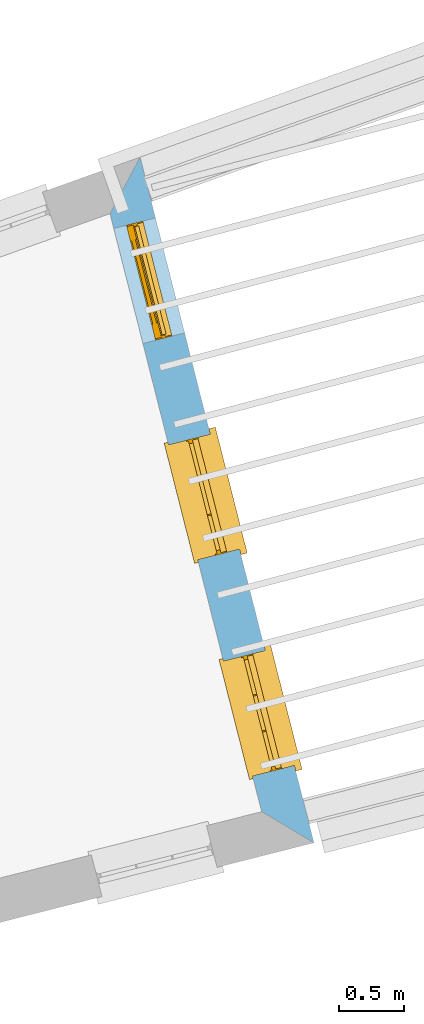
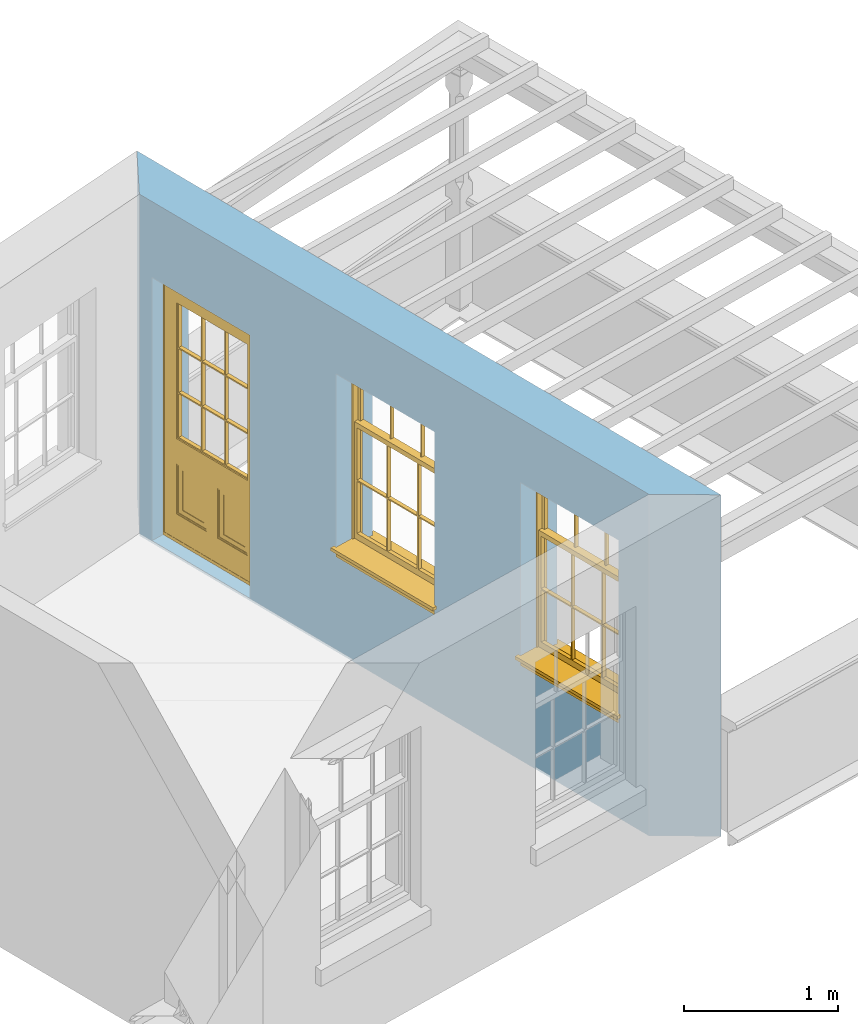
# One storey, part 8 of 10: 2 windows, 1 door, 3 openings, plus 1 element that does not belong to this part.
"""IFC2X3 building model written with IfcOpenShell, lengths in metres."""

import ifcopenshell
import ifcopenshell.guid

model = None  # the IFC model being written
_history = None  # IfcOwnerHistory: only IFC2X3 demands one
_inside = {}  # id of a spatial element -> (the spatial element, [elements in it])
_under = {}  # id of a project, library or spatial element -> (it, [spatial elements below it])
_declared = {}  # id of a project -> (the project, [libraries it declares])
_typed = {}  # id of a type object -> (the type object, [elements of that type])
_made_of = {}  # id of a material, layer set ... -> (it, [elements and type objects made of it])


def new_model(schema):
    """Start an empty IFC model of exactly this schema.

    Asked for "IFC4X3", IfcOpenShell would pick the latest addendum, in which some entities
    have other attributes; the version numbers below select the first issue.
    IFC2X3 requires an IfcOwnerHistory on every rooted entity: one is made here for all.
    """
    global model, _history
    if schema == "IFC4X3":
        model = ifcopenshell.file(schema_version=(4, 3, 0, 0))
    else:
        model = ifcopenshell.file(schema=schema)
    _inside.clear()
    _under.clear()
    _declared.clear()
    _typed.clear()
    _made_of.clear()
    _history = None
    if model.schema == "IFC2X3":
        org = make("IfcOrganization", Name="unknown")
        user = make(
            "IfcPersonAndOrganization",
            ThePerson=make("IfcPerson", FamilyName="unknown"),
            TheOrganization=org,
        )
        app = make(
            "IfcApplication",
            ApplicationDeveloper=org,
            Version="unknown",
            ApplicationFullName="unknown",
            ApplicationIdentifier="unknown",
        )
        _history = make(
            "IfcOwnerHistory",
            OwningUser=user,
            OwningApplication=app,
            ChangeAction="ADDED",
            CreationDate=0,
        )
    return model


def make(cls, **values):
    """One entity of the class cls with the attributes given. An attribute that is None is left unset."""
    return model.create_entity(
        cls, **{name: value for name, value in values.items() if value is not None}
    )


def rooted(cls, **values):
    """An entity with a GlobalId (a new one), such as an element, a storey or a relation."""
    return make(cls, GlobalId=ifcopenshell.guid.new(), OwnerHistory=_history, **values)


def si_unit(unit_type, name, prefix=None):
    """IfcSIUnit, for example si_unit("LENGTHUNIT", "METRE", prefix="MILLI")."""
    return make("IfcSIUnit", UnitType=unit_type, Prefix=prefix, Name=name)


def assignment(units):
    """IfcUnitAssignment: the units of a project."""
    return None if units is None else make("IfcUnitAssignment", Units=units)


def point(xyz):
    """IfcCartesianPoint."""
    return None if xyz is None else make("IfcCartesianPoint", Coordinates=xyz)


def direction(xyz):
    """IfcDirection."""
    return None if xyz is None else make("IfcDirection", DirectionRatios=xyz)


def frame(location, z_axis=None, x_axis=None):
    """IfcAxis2Placement3D, a coordinate frame: its origin and axes. An axis left out is left unset."""
    return make(
        "IfcAxis2Placement3D",
        Location=point(location),
        Axis=direction(z_axis),
        RefDirection=direction(x_axis),
    )


def origin():
    """The frame at (0, 0, 0) with its axes left unset."""
    return frame((0.0, 0.0, 0.0))


def place(relative_to, where):
    """IfcLocalPlacement: puts the frame where relative to a parent placement (None: the world)."""
    return make(
        "IfcLocalPlacement", PlacementRelTo=relative_to, RelativePlacement=where
    )


def context(
    kind, dimensions, precision=None, world=None, true_north=None, identifier=None
):
    """IfcGeometricRepresentationContext, for example the 3D "Model" context."""
    return make(
        "IfcGeometricRepresentationContext",
        ContextIdentifier=identifier,
        ContextType=kind,
        CoordinateSpaceDimension=dimensions,
        Precision=precision,
        WorldCoordinateSystem=world,
        TrueNorth=true_north,
    )


def subcontext(parent, identifier, kind, view, scale=None):
    """IfcGeometricRepresentationSubContext, for example "Body" below "Model"."""
    return make(
        "IfcGeometricRepresentationSubContext",
        ContextIdentifier=identifier,
        ContextType=kind,
        ParentContext=parent,
        TargetScale=scale,
        TargetView=view,
    )


def project(units=None, contexts=None):
    """IfcProject with its units and contexts."""
    return rooted(
        "IfcProject",
        Name="project",
        RepresentationContexts=contexts,
        UnitsInContext=assignment(units),
    )


def spatial(cls, under=None, at=None, **own):
    """A site, building, storey or space (cls), placed at a placement, below another one or the project."""
    s = rooted(cls, ObjectPlacement=at, **own)
    if under is not None:
        _under.setdefault(under.id(), (under, []))[1].append(s)
    return s


def polyline(points):
    """IfcPolyline through the points."""
    return make("IfcPolyline", Points=[point(p) for p in points])


def outline(outer, holes=None, kind="AREA"):
    """IfcArbitraryClosedProfileDef: a profile drawn as a closed curve; with holes, ...WithVoids."""
    if holes is None:
        return make("IfcArbitraryClosedProfileDef", ProfileType=kind, OuterCurve=outer)
    return make(
        "IfcArbitraryProfileDefWithVoids",
        ProfileType=kind,
        OuterCurve=outer,
        InnerCurves=holes,
    )


def extrude(swept, where, along, depth):
    """IfcExtrudedAreaSolid: the profile swept, set in the frame where, extruded along a direction by depth."""
    return make(
        "IfcExtrudedAreaSolid",
        SweptArea=swept,
        Position=where,
        ExtrudedDirection=direction(along),
        Depth=depth,
    )


def faces_of(points, faces, orient=None, outer=None):
    """IfcFace entities. A face is a list of loops; a loop is a list of indices into points, from 0.

    orient and outer hold one flag for each loop. By default every Orientation is true, the
    first loop of a face is its IfcFaceOuterBound and the others are IfcFaceBound.
    """
    made = []
    for i, loops in enumerate(faces):
        bounds = []
        for j, loop in enumerate(loops):
            is_outer = j == 0 if outer is None else outer[i][j]
            bounds.append(
                make(
                    "IfcFaceOuterBound" if is_outer else "IfcFaceBound",
                    Bound=make("IfcPolyLoop", Polygon=[points[k] for k in loop]),
                    Orientation=True if orient is None else orient[i][j],
                )
            )
        made.append(make("IfcFace", Bounds=bounds))
    return made


def faceted_brep(points, faces, orient=None, outer=None, voids=None):
    """IfcFacetedBrep: a solid bounded by flat faces; with voids (closed shells), ...WithVoids."""
    shared = [point(p) for p in points]
    hull = make("IfcClosedShell", CfsFaces=faces_of(shared, faces, orient, outer))
    if voids is None:
        return make("IfcFacetedBrep", Outer=hull)
    return make(
        "IfcFacetedBrepWithVoids",
        Outer=hull,
        Voids=[
            make(cls, CfsFaces=faces_of(shared, fs, o, b)) for cls, fs, o, b in voids
        ],
    )


def shape(context_of_items, identifier, shape_type, items):
    """IfcShapeRepresentation: the items that make up one representation, for example the "Body"."""
    return make(
        "IfcShapeRepresentation",
        ContextOfItems=context_of_items,
        RepresentationIdentifier=identifier,
        RepresentationType=shape_type,
        Items=items,
    )


def material(Name=None, Category=None):
    """IfcMaterial."""
    return make("IfcMaterial", Name=Name, Category=Category)


def layer(
    of_material, thickness, ventilated=None, Name=None, Category=None, Priority=None
):
    """IfcMaterialLayer: one layer of a wall or slab, of a material (None: an air gap)."""
    return make(
        "IfcMaterialLayer",
        Material=of_material,
        LayerThickness=thickness,
        IsVentilated=ventilated,
        Name=Name,
        Category=Category,
        Priority=Priority,
    )


def layer_set(layers, Name=None):
    """IfcMaterialLayerSet."""
    return make("IfcMaterialLayerSet", MaterialLayers=layers, LayerSetName=Name)


def layer_usage(for_layer_set, set_direction, sense, offset, extent=None):
    """IfcMaterialLayerSetUsage: how a layer set lies in its element."""
    return make(
        "IfcMaterialLayerSetUsage",
        ForLayerSet=for_layer_set,
        LayerSetDirection=set_direction,
        DirectionSense=sense,
        OffsetFromReferenceLine=offset,
        ReferenceExtent=extent,
    )


def made_of(thing, what):
    """Note that an element or type object is made of a material, layer set ...; save() writes the relation."""
    if what is not None:
        _made_of.setdefault(what.id(), (what, []))[1].append(thing)
    return thing


def element(
    cls,
    number,
    at=None,
    inside=None,
    cuts=None,
    type_object=None,
    material=None,
    context=None,
    identifier="Body",
    shape_type=None,
    held_by="IfcProductDefinitionShape",
    body=None,
    shapes=None,
    **own,
):
    """One element of the class cls, such as IfcWall. Its Tag is "e" and its number.

    at: its placement. inside: the storey or other place that contains it. cuts: it is an
    opening in that element (IfcRelVoidsElement). A single representation is given by context,
    identifier, shape_type and body (its items); several are given by shapes. held_by: the class
    of the entity that holds the representations. save() writes the other relations.
    """
    e = rooted(cls, Tag="e%d" % number, ObjectPlacement=at, **own)
    if body is not None:
        shapes = [shape(context, identifier, shape_type, body)]
    if shapes is not None:
        e.Representation = make(held_by, Representations=shapes)
    if inside is not None:
        _inside.setdefault(inside.id(), (inside, []))[1].append(e)
    if cuts is not None:
        rooted(
            "IfcRelVoidsElement", RelatingBuildingElement=cuts, RelatedOpeningElement=e
        )
    if type_object is not None:
        _typed.setdefault(type_object.id(), (type_object, []))[1].append(e)
    return made_of(e, material)


def fill(opening, filler):
    """IfcRelFillsElement: the door or window that sits in an opening."""
    return rooted(
        "IfcRelFillsElement",
        RelatingOpeningElement=opening,
        RelatedBuildingElement=filler,
    )


def aggregate(whole, parts):
    """IfcRelAggregates: a whole, such as a stair, and the parts it consists of."""
    return rooted("IfcRelAggregates", RelatingObject=whole, RelatedObjects=parts)


def save(model, path):
    """Write the relations noted so far, then the file.

    IfcRelAggregates (storeys below a building ...), IfcRelContainedInSpatialStructure (elements
    in a storey), IfcRelDefinesByType, IfcRelAssociatesMaterial and IfcRelDeclares: one each for
    every whole, place, type object, material and project.
    """
    for whole, parts in _under.values():
        aggregate(whole, parts)
    for where, things in _inside.values():
        rooted(
            "IfcRelContainedInSpatialStructure",
            RelatedElements=things,
            RelatingStructure=where,
        )
    for kind, things in _typed.values():
        rooted("IfcRelDefinesByType", RelatedObjects=things, RelatingType=kind)
    for what, things in _made_of.values():
        rooted("IfcRelAssociatesMaterial", RelatedObjects=things, RelatingMaterial=what)
    for by, libraries in _declared.values():
        rooted("IfcRelDeclares", RelatingContext=by, RelatedDefinitions=libraries)
    model.write(path)


model = new_model("IFC2X3")

# Units and contexts
model_context = context("Model", 3, world=origin())
body_context = subcontext(model_context, "Body", "Model", "MODEL_VIEW")
ifc_project = project(units=[si_unit("PLANEANGLEUNIT", "RADIAN"), si_unit("MASSUNIT", "GRAM", prefix="KILO"), si_unit("FORCEUNIT", "NEWTON", prefix="KILO"), si_unit("LENGTHUNIT", "METRE")], contexts=[model_context])

# Site, building, storey
site_placement = place(None, origin())
site = spatial("IfcSite", under=ifc_project, at=site_placement, CompositionType="ELEMENT")
building_placement = place(None, origin())
building = spatial("IfcBuilding", under=site, at=building_placement, Name="Building plot-13", CompositionType="ELEMENT")
storey_placement = place(None, frame((0.0, 0.0, 9.55)))
storey = spatial("IfcBuildingStorey", under=building, at=storey_placement, Name="Floor 2", CompositionType="ELEMENT", Elevation=9.55)

# Wall, openings, windows, door
ifc_material = material(Name="Masonry")
ifc_layer = layer(ifc_material, 0.33, ventilated=False)
ifc_layer_set = layer_set([ifc_layer], Name="My Wall")
ifc_layer_usage = layer_usage(ifc_layer_set, "AXIS2", "NEGATIVE", 0.08)
wall_placement = place(storey_placement, origin())
wall = element("IfcWallStandardCase", 1, at=wall_placement, inside=storey, material=ifc_layer_usage, Name="exterior", context=body_context, shape_type="SweptSolid", body=[
    extrude(outline(polyline([(76.8445718371103, 46.4530457942866), (77.2455722633567, 46.2143018767719), (75.9129314952901, 51.4686328142499), (75.6822868035305, 51.0356987915879), (76.8445718371103, 46.4530457942866)])), origin(), (0.0, 0.0, 1.0), 2.7),
])
opening_1_placement = place(storey_placement, frame((0.0, 0.0, 0.75)))
opening_1 = element("IfcOpeningElement", 2, at=opening_1_placement, cuts=wall, Name="Opening", ObjectType="Opening", context=body_context, shape_type="SweptSolid", body=[
    extrude(outline(polyline([(77.0953728860989, 46.8065074085449), (76.8716555786053, 47.6885791552457), (76.5517834067248, 47.6074509008799), (76.7755007142184, 46.7253791541791), (77.0953728860989, 46.8065074085449)])), origin(), (0.0, 0.0, 1.0), 1.445),
])
opening_2_placement = place(storey_placement, frame((0.0, 0.0, 0.75)))
opening_2 = element("IfcOpeningElement", 3, at=opening_2_placement, cuts=wall, Name="Opening", ObjectType="Opening", context=body_context, shape_type="SweptSolid", body=[
    extrude(outline(polyline([(76.6749810225669, 48.464026844653), (76.4512637150733, 49.3460985913538), (76.1313915431928, 49.264970336988), (76.3551088506864, 48.3828985902872), (76.6749810225669, 48.464026844653)])), origin(), (0.0, 0.0, 1.0), 1.445),
])
opening_3_placement = place(storey_placement, frame((0.0, 0.0, 0.0199999999999996)))
opening_3 = element("IfcOpeningElement", 4, at=opening_3_placement, cuts=wall, Name="Opening", ObjectType="Opening", context=body_context, shape_type="SweptSolid", body=[
    extrude(outline(polyline([(76.2545891590349, 50.1215462807611), (76.0308718515412, 51.0036180274619), (75.7109996796607, 50.9224897730961), (75.9347169871544, 50.0404180263953), (76.2545891590349, 50.1215462807611)])), origin(), (0.0, 0.0, 1.0), 2.08),
])
window_1_placement = place(storey_placement, frame((76.8530454831591, 46.7450466097829, 0.75), z_axis=(0.0, 0.0, 1.0), x_axis=(-0.223717307493644, 0.882071746700802, 0.0)))
window_1 = element("IfcWindow", 5, at=window_1_placement, inside=storey, Name="bedroom outside window", OverallHeight=1.445, OverallWidth=0.91, context=body_context, shape_type="Brep", held_by="IfcProductRepresentation", body=[
    faceted_brep([(0.876875, -0.105, 0.999097), (0.876875, -0.105, 1.411875), (0.9, -0.105, 1.435), (0.033125, -0.105, 1.411875), (0.033125, -0.105, 0.999097), (0.01, -0.105, 1.435), (0.033125, -0.135, 1.411875), (0.01, -0.135, 1.435), (0.033125, -0.135, 0.999097), (0.876875, -0.135, 1.411875), (0.876875, -0.135, 0.999097), (0.9, -0.135, 1.435), (0.033125, -0.105, 0.960972), (0.01, -0.105, 0.960972), (0.033125, -0.105, 0.548195), (0.876875, -0.105, 0.960972), (0.876875, -0.105, 0.548195), (0.9, -0.105, 0.960972), (0.876875, -0.105, 0.538195), (0.876875, -0.105, 0.125417), (0.9, -0.105, 0.077167), (0.033125, -0.105, 0.125417), (0.033125, -0.105, 0.538195), (0.01, -0.105, 0.077167), (0.9, -0.135, 0.960972), (0.01, -0.135, 0.960972), (-0.0425, -0.25, 0.01), (-0.0425, -0.3, 0.001667), (0.0, -0.25, 0.01), (0.9525, -0.25, 0.01), (0.91, -0.25, 0.01), (0.9525, -0.3, 0.001667), (-0.02, 0.08, 0.077167), (0.0, 0.08, 0.077167), (-0.02, 0.11, 0.077167), (0.0, -0.06, 0.077167), (0.01, -0.06, 0.077167), (0.91, -0.06, 0.077167), (0.91, 0.08, 0.077167), (0.9, -0.06, 0.077167), (0.93, 0.08, 0.077167), (0.93, 0.11, 0.077167), (0.01, -0.105, 0.999097), (0.01, -0.075, 0.999097), (0.9, -0.105, 0.999097), (0.9, -0.075, 0.999097), (0.876875, -0.075, 0.125417), (0.876875, -0.075, 0.538195), (0.9, -0.075, 0.077167), (0.876875, -0.075, 0.548195), (0.876875, -0.075, 0.960972), (0.033125, -0.075, 0.125417), (0.01, -0.075, 0.077167), (0.033125, -0.075, 0.538195), (0.033125, -0.075, 0.960972), (0.033125, -0.075, 0.548195), (-0.02, 0.08, 0.052167), (-0.02, 0.11, 0.052167), (0.93, 0.11, 0.052167), (0.93, 0.08, 0.052167), (0.91, 0.08, 0.052167), (0.0, 0.08, 0.052167), (0.91, -0.15, 0.026667), (0.0, -0.15, 0.026667), (-0.0425, -0.3, -0.123333), (0.9525, -0.3, -0.123333), (-0.0425, -0.25, -0.123333), (0.9525, -0.25, -0.123333), (0.01, -0.06, 1.435), (0.9, -0.06, 1.435), (0.0, -0.06, 1.445), (0.91, -0.06, 1.445), (0.01, -0.15, 0.077167), (0.9, -0.15, 0.077167), (0.592292, -0.105, 0.125417), (0.592292, -0.075, 0.125417), (0.317708, -0.075, 0.125417), (0.317708, -0.105, 0.125417), (0.592292, -0.105, 0.548195), (0.317708, -0.105, 0.548195), (0.317708, -0.105, 0.538195), (0.592292, -0.105, 0.538195), (0.592292, -0.075, 0.548195), (0.317708, -0.075, 0.548195), (0.602292, -0.075, 0.548195), (0.602292, -0.105, 0.548195), (0.317708, -0.075, 0.538195), (0.307708, -0.075, 0.125417), (0.307708, -0.075, 0.538195), (0.602292, -0.075, 0.538195), (0.602292, -0.075, 0.125417), (0.592292, -0.075, 0.538195), (0.307708, -0.075, 0.548195), (0.317708, -0.075, 0.960972), (0.307708, -0.075, 0.960972), (0.602292, -0.075, 0.960972), (0.592292, -0.075, 0.960972), (0.307708, -0.105, 0.538195), (0.307708, -0.105, 0.125417), (0.307708, -0.105, 0.548195), (0.307708, -0.105, 0.960972), (0.592292, -0.105, 0.960972), (0.317708, -0.105, 0.960972), (0.602292, -0.105, 0.960972), (0.602292, -0.105, 0.538195), (0.602292, -0.105, 0.125417), (0.317708, -0.135, 1.411875), (0.307708, -0.135, 1.411875), (0.307708, -0.135, 0.999097), (0.317708, -0.135, 0.999097), (0.602292, -0.135, 1.411875), (0.592292, -0.135, 1.411875), (0.592292, -0.135, 0.999097), (0.602292, -0.135, 0.999097), (0.317708, -0.105, 0.999097), (0.307708, -0.105, 0.999097), (0.307708, -0.105, 1.411875), (0.317708, -0.105, 1.411875), (0.602292, -0.105, 0.999097), (0.592292, -0.105, 0.999097), (0.592292, -0.105, 1.411875), (0.602292, -0.105, 1.411875), (0.91, -0.15, 1.445), (0.9, -0.15, 1.435), (0.01, -0.15, 1.435), (0.0, -0.15, 1.445), (0.91, -0.25, 0.0), (0.0, -0.25, 0.0), (0.91, 0.08, 0.0), (0.0, 0.08, 0.0)], [[[0, 1, 2]], [[3, 4, 5]], [[6, 7, 8]], [[9, 10, 11]], [[12, 13, 14]], [[15, 16, 17]], [[18, 19, 20]], [[21, 22, 23]], [[24, 15, 17]], [[13, 12, 25]], [[26, 27, 28]], [[29, 30, 31]], [[32, 33, 34]], [[35, 36, 33]], [[37, 38, 39]], [[40, 41, 38]], [[42, 4, 43]], [[44, 45, 0]], [[46, 47, 48]], [[49, 50, 45]], [[51, 52, 53]], [[54, 55, 43]], [[38, 33, 36, 39]], [[41, 34, 33, 38]], [[56, 32, 34, 57]], [[57, 34, 41, 58]], [[58, 41, 40, 59]], [[57, 58, 60, 61]], [[52, 48, 39, 36]], [[62, 63, 28, 30]], [[27, 31, 30, 28]], [[27, 64, 65, 31]], [[66, 67, 65, 64]], [[2, 5, 68, 69]], [[68, 70, 71, 69]], [[20, 23, 72, 73]], [[73, 72, 63, 62]], [[74, 75, 76, 77]], [[78, 79, 80, 81]], [[78, 82, 83, 79]], [[16, 49, 84, 85]], [[86, 76, 87, 88]], [[89, 90, 75, 91]], [[92, 88, 53, 55]], [[82, 91, 86, 83]], [[93, 83, 92, 94]], [[95, 84, 82, 96]], [[89, 84, 49, 47]], [[97, 88, 87, 98]], [[22, 53, 88, 97]], [[81, 91, 75, 74]], [[80, 86, 91, 81]], [[77, 76, 86, 80]], [[99, 92, 55, 14]], [[100, 94, 92, 99]], [[101, 96, 82, 78]], [[79, 83, 93, 102]], [[85, 84, 95, 103]], [[104, 89, 47, 18]], [[105, 90, 89, 104]], [[104, 18, 16, 85]], [[80, 97, 98, 77]], [[104, 81, 74, 105]], [[103, 101, 78, 85]], [[99, 14, 22, 97]], [[102, 100, 99, 79]], [[106, 107, 108, 109]], [[110, 111, 112, 113]], [[114, 115, 116, 117]], [[118, 119, 120, 121]], [[107, 116, 115, 108]], [[111, 120, 119, 112]], [[109, 114, 117, 106]], [[113, 118, 121, 110]], [[85, 78, 81, 104]], [[84, 89, 91, 82]], [[83, 86, 88, 92]], [[79, 99, 97, 80]], [[109, 112, 119, 114]], [[102, 93, 96, 101]], [[106, 117, 120, 111]], [[98, 87, 51, 21]], [[6, 3, 116, 107]], [[110, 121, 1, 9]], [[19, 46, 90, 105]], [[26, 66, 64, 27]], [[29, 31, 65, 67]], [[25, 24, 112, 109]], [[11, 7, 106, 111]], [[75, 48, 52, 76]], [[43, 45, 96, 93]], [[45, 43, 114, 119]], [[5, 2, 120, 117]], [[24, 25, 102, 101]], [[42, 5, 4]], [[2, 44, 0]], [[49, 45, 48, 47]], [[52, 43, 55, 53]], [[14, 13, 23, 22]], [[20, 17, 16, 18]], [[24, 11, 10]], [[25, 8, 7]], [[8, 4, 3, 6]], [[9, 1, 0, 10]], [[15, 50, 49, 16]], [[18, 47, 46, 19]], [[21, 51, 53, 22]], [[14, 55, 54, 12]], [[44, 2, 69, 45]], [[68, 5, 42, 43]], [[36, 35, 70, 68]], [[39, 69, 71, 37]], [[62, 122, 123, 73]], [[63, 72, 124, 125]], [[8, 108, 115, 4]], [[113, 10, 0, 118]], [[94, 100, 12, 54]], [[17, 20, 73, 24]], [[72, 23, 13, 25]], [[52, 36, 68, 43]], [[69, 39, 48, 45]], [[11, 24, 73, 123]], [[7, 124, 72, 25]], [[23, 77, 98]], [[98, 21, 23]], [[105, 74, 20]], [[20, 19, 105]], [[20, 74, 77, 23]], [[113, 112, 24]], [[24, 10, 113]], [[25, 109, 108]], [[108, 8, 25]], [[110, 9, 11]], [[11, 111, 110]], [[7, 6, 107]], [[107, 106, 7]], [[5, 117, 116]], [[116, 3, 5]], [[121, 120, 2]], [[2, 1, 121]], [[11, 123, 124, 7]], [[122, 125, 124, 123]], [[43, 93, 94]], [[94, 54, 43]], [[96, 45, 95]], [[50, 95, 45]], [[15, 103, 95, 50]], [[48, 75, 90]], [[90, 46, 48]], [[87, 76, 52]], [[52, 51, 87]], [[103, 15, 24]], [[24, 101, 103]], [[100, 102, 25]], [[25, 12, 100]], [[115, 114, 43]], [[43, 4, 115]], [[118, 0, 45]], [[45, 119, 118]], [[71, 70, 125, 122]], [[70, 35, 63, 125]], [[122, 62, 37, 71]], [[126, 67, 66, 127]], [[60, 58, 59]], [[38, 60, 59, 40]], [[61, 56, 57]], [[32, 56, 61, 33]], [[61, 60, 128, 129]], [[62, 60, 38, 37]], [[126, 128, 60, 62]], [[33, 61, 63, 35]], [[61, 129, 127, 63]], [[128, 126, 127, 129]], [[28, 127, 66, 26]], [[63, 127, 28]], [[29, 67, 126, 30]], [[30, 126, 62]]]),
])
fill(opening_1, window_1)
window_2_placement = place(storey_placement, frame((76.4326536196271, 48.402566045891, 0.75), z_axis=(0.0, 0.0, 1.0), x_axis=(-0.223717307493644, 0.882071746700795, 0.0)))
window_2 = element("IfcWindow", 6, at=window_2_placement, inside=storey, Name="bedroom outside window", OverallHeight=1.445, OverallWidth=0.91, context=body_context, shape_type="Brep", held_by="IfcProductRepresentation", body=[
    faceted_brep([(0.876875, -0.105, 0.999097), (0.876875, -0.105, 1.411875), (0.9, -0.105, 1.435), (0.033125, -0.105, 1.411875), (0.033125, -0.105, 0.999097), (0.01, -0.105, 1.435), (0.033125, -0.135, 1.411875), (0.01, -0.135, 1.435), (0.033125, -0.135, 0.999097), (0.876875, -0.135, 1.411875), (0.876875, -0.135, 0.999097), (0.9, -0.135, 1.435), (0.033125, -0.105, 0.960972), (0.01, -0.105, 0.960972), (0.033125, -0.105, 0.548195), (0.876875, -0.105, 0.960972), (0.876875, -0.105, 0.548195), (0.9, -0.105, 0.960972), (0.876875, -0.105, 0.538195), (0.876875, -0.105, 0.125417), (0.9, -0.105, 0.077167), (0.033125, -0.105, 0.125417), (0.033125, -0.105, 0.538195), (0.01, -0.105, 0.077167), (0.9, -0.135, 0.960972), (0.01, -0.135, 0.960972), (-0.0425, -0.25, 0.01), (-0.0425, -0.3, 0.001667), (0.0, -0.25, 0.01), (0.9525, -0.25, 0.01), (0.91, -0.25, 0.01), (0.9525, -0.3, 0.001667), (-0.02, 0.08, 0.077167), (0.0, 0.08, 0.077167), (-0.02, 0.11, 0.077167), (0.0, -0.06, 0.077167), (0.01, -0.06, 0.077167), (0.91, -0.06, 0.077167), (0.91, 0.08, 0.077167), (0.9, -0.06, 0.077167), (0.93, 0.08, 0.077167), (0.93, 0.11, 0.077167), (0.01, -0.105, 0.999097), (0.01, -0.075, 0.999097), (0.9, -0.105, 0.999097), (0.9, -0.075, 0.999097), (0.876875, -0.075, 0.125417), (0.876875, -0.075, 0.538195), (0.9, -0.075, 0.077167), (0.876875, -0.075, 0.548195), (0.876875, -0.075, 0.960972), (0.033125, -0.075, 0.125417), (0.01, -0.075, 0.077167), (0.033125, -0.075, 0.538195), (0.033125, -0.075, 0.960972), (0.033125, -0.075, 0.548195), (-0.02, 0.08, 0.052167), (-0.02, 0.11, 0.052167), (0.93, 0.11, 0.052167), (0.93, 0.08, 0.052167), (0.91, 0.08, 0.052167), (0.0, 0.08, 0.052167), (0.91, -0.15, 0.026667), (0.0, -0.15, 0.026667), (-0.0425, -0.3, -0.123333), (0.9525, -0.3, -0.123333), (-0.0425, -0.25, -0.123333), (0.9525, -0.25, -0.123333), (0.01, -0.06, 1.435), (0.9, -0.06, 1.435), (0.0, -0.06, 1.445), (0.91, -0.06, 1.445), (0.01, -0.15, 0.077167), (0.9, -0.15, 0.077167), (0.592292, -0.105, 0.125417), (0.592292, -0.075, 0.125417), (0.317708, -0.075, 0.125417), (0.317708, -0.105, 0.125417), (0.592292, -0.105, 0.548195), (0.317708, -0.105, 0.548195), (0.317708, -0.105, 0.538195), (0.592292, -0.105, 0.538195), (0.592292, -0.075, 0.548195), (0.317708, -0.075, 0.548195), (0.602292, -0.075, 0.548195), (0.602292, -0.105, 0.548195), (0.317708, -0.075, 0.538195), (0.307708, -0.075, 0.125417), (0.307708, -0.075, 0.538195), (0.602292, -0.075, 0.538195), (0.602292, -0.075, 0.125417), (0.592292, -0.075, 0.538195), (0.307708, -0.075, 0.548195), (0.317708, -0.075, 0.960972), (0.307708, -0.075, 0.960972), (0.602292, -0.075, 0.960972), (0.592292, -0.075, 0.960972), (0.307708, -0.105, 0.538195), (0.307708, -0.105, 0.125417), (0.307708, -0.105, 0.548195), (0.307708, -0.105, 0.960972), (0.592292, -0.105, 0.960972), (0.317708, -0.105, 0.960972), (0.602292, -0.105, 0.960972), (0.602292, -0.105, 0.538195), (0.602292, -0.105, 0.125417), (0.317708, -0.135, 1.411875), (0.307708, -0.135, 1.411875), (0.307708, -0.135, 0.999097), (0.317708, -0.135, 0.999097), (0.602292, -0.135, 1.411875), (0.592292, -0.135, 1.411875), (0.592292, -0.135, 0.999097), (0.602292, -0.135, 0.999097), (0.317708, -0.105, 0.999097), (0.307708, -0.105, 0.999097), (0.307708, -0.105, 1.411875), (0.317708, -0.105, 1.411875), (0.602292, -0.105, 0.999097), (0.592292, -0.105, 0.999097), (0.592292, -0.105, 1.411875), (0.602292, -0.105, 1.411875), (0.91, -0.15, 1.445), (0.9, -0.15, 1.435), (0.01, -0.15, 1.435), (0.0, -0.15, 1.445), (0.91, -0.25, 0.0), (0.0, -0.25, 0.0), (0.91, 0.08, 0.0), (0.0, 0.08, 0.0)], [[[0, 1, 2]], [[3, 4, 5]], [[6, 7, 8]], [[9, 10, 11]], [[12, 13, 14]], [[15, 16, 17]], [[18, 19, 20]], [[21, 22, 23]], [[24, 15, 17]], [[13, 12, 25]], [[26, 27, 28]], [[29, 30, 31]], [[32, 33, 34]], [[35, 36, 33]], [[37, 38, 39]], [[40, 41, 38]], [[42, 4, 43]], [[44, 45, 0]], [[46, 47, 48]], [[49, 50, 45]], [[51, 52, 53]], [[54, 55, 43]], [[38, 33, 36, 39]], [[41, 34, 33, 38]], [[56, 32, 34, 57]], [[57, 34, 41, 58]], [[58, 41, 40, 59]], [[57, 58, 60, 61]], [[52, 48, 39, 36]], [[62, 63, 28, 30]], [[27, 31, 30, 28]], [[27, 64, 65, 31]], [[66, 67, 65, 64]], [[2, 5, 68, 69]], [[68, 70, 71, 69]], [[20, 23, 72, 73]], [[73, 72, 63, 62]], [[74, 75, 76, 77]], [[78, 79, 80, 81]], [[78, 82, 83, 79]], [[16, 49, 84, 85]], [[86, 76, 87, 88]], [[89, 90, 75, 91]], [[92, 88, 53, 55]], [[82, 91, 86, 83]], [[93, 83, 92, 94]], [[95, 84, 82, 96]], [[89, 84, 49, 47]], [[97, 88, 87, 98]], [[22, 53, 88, 97]], [[81, 91, 75, 74]], [[80, 86, 91, 81]], [[77, 76, 86, 80]], [[99, 92, 55, 14]], [[100, 94, 92, 99]], [[101, 96, 82, 78]], [[79, 83, 93, 102]], [[85, 84, 95, 103]], [[104, 89, 47, 18]], [[105, 90, 89, 104]], [[104, 18, 16, 85]], [[80, 97, 98, 77]], [[104, 81, 74, 105]], [[103, 101, 78, 85]], [[99, 14, 22, 97]], [[102, 100, 99, 79]], [[106, 107, 108, 109]], [[110, 111, 112, 113]], [[114, 115, 116, 117]], [[118, 119, 120, 121]], [[107, 116, 115, 108]], [[111, 120, 119, 112]], [[109, 114, 117, 106]], [[113, 118, 121, 110]], [[85, 78, 81, 104]], [[84, 89, 91, 82]], [[83, 86, 88, 92]], [[79, 99, 97, 80]], [[109, 112, 119, 114]], [[102, 93, 96, 101]], [[106, 117, 120, 111]], [[98, 87, 51, 21]], [[6, 3, 116, 107]], [[110, 121, 1, 9]], [[19, 46, 90, 105]], [[26, 66, 64, 27]], [[29, 31, 65, 67]], [[25, 24, 112, 109]], [[11, 7, 106, 111]], [[75, 48, 52, 76]], [[43, 45, 96, 93]], [[45, 43, 114, 119]], [[5, 2, 120, 117]], [[24, 25, 102, 101]], [[42, 5, 4]], [[2, 44, 0]], [[49, 45, 48, 47]], [[52, 43, 55, 53]], [[14, 13, 23, 22]], [[20, 17, 16, 18]], [[24, 11, 10]], [[25, 8, 7]], [[8, 4, 3, 6]], [[9, 1, 0, 10]], [[15, 50, 49, 16]], [[18, 47, 46, 19]], [[21, 51, 53, 22]], [[14, 55, 54, 12]], [[44, 2, 69, 45]], [[68, 5, 42, 43]], [[36, 35, 70, 68]], [[39, 69, 71, 37]], [[62, 122, 123, 73]], [[63, 72, 124, 125]], [[8, 108, 115, 4]], [[113, 10, 0, 118]], [[94, 100, 12, 54]], [[17, 20, 73, 24]], [[72, 23, 13, 25]], [[52, 36, 68, 43]], [[69, 39, 48, 45]], [[11, 24, 73, 123]], [[7, 124, 72, 25]], [[23, 77, 98]], [[98, 21, 23]], [[105, 74, 20]], [[20, 19, 105]], [[20, 74, 77, 23]], [[113, 112, 24]], [[24, 10, 113]], [[25, 109, 108]], [[108, 8, 25]], [[110, 9, 11]], [[11, 111, 110]], [[7, 6, 107]], [[107, 106, 7]], [[5, 117, 116]], [[116, 3, 5]], [[121, 120, 2]], [[2, 1, 121]], [[11, 123, 124, 7]], [[122, 125, 124, 123]], [[43, 93, 94]], [[94, 54, 43]], [[96, 45, 95]], [[50, 95, 45]], [[15, 103, 95, 50]], [[48, 75, 90]], [[90, 46, 48]], [[87, 76, 52]], [[52, 51, 87]], [[103, 15, 24]], [[24, 101, 103]], [[100, 102, 25]], [[25, 12, 100]], [[115, 114, 43]], [[43, 4, 115]], [[118, 0, 45]], [[45, 119, 118]], [[71, 70, 125, 122]], [[70, 35, 63, 125]], [[122, 62, 37, 71]], [[126, 67, 66, 127]], [[60, 58, 59]], [[38, 60, 59, 40]], [[61, 56, 57]], [[32, 56, 61, 33]], [[61, 60, 128, 129]], [[62, 60, 38, 37]], [[126, 128, 60, 62]], [[33, 61, 63, 35]], [[61, 129, 127, 63]], [[128, 126, 127, 129]], [[28, 127, 66, 26]], [[63, 127, 28]], [[29, 67, 126, 30]], [[30, 126, 62]]]),
])
fill(opening_2, window_2)
door_placement = place(storey_placement, frame((76.0122617560951, 50.0600854819991, 0.0199999999999996), z_axis=(0.0, 0.0, 1.0), x_axis=(-0.223717307493658, 0.882071746700795, 0.0)))
door = element("IfcDoor", 7, at=door_placement, inside=storey, Name="bedroom outside door", OverallHeight=2.08, OverallWidth=0.91, context=body_context, shape_type="Brep", held_by="IfcProductRepresentation", body=[
    faceted_brep([(0.545, -0.055, 0.265), (0.745, -0.055, 0.265), (0.745, -0.05, 0.265), (0.545, -0.05, 0.265), (0.745, -0.05, 0.58), (0.545, -0.05, 0.58), (0.545, -0.055, 0.58), (0.515, -0.06, 0.235), (0.775, -0.06, 0.235), (0.745, -0.055, 0.58), (0.515, -0.06, 0.61), (0.515, -0.065, 0.235), (0.775, -0.065, 0.235), (0.775, -0.06, 0.61), (0.515, -0.065, 0.61), (0.785, -0.065, 0.225), (0.505, -0.065, 0.225), (0.775, -0.065, 0.61), (0.505, -0.065, 0.62), (0.785, -0.065, 0.62), (0.505, -0.07, 0.225), (0.785, -0.07, 0.225), (0.505, -0.07, 0.62), (0.785, -0.07, 0.62), (0.883, -0.07, 0.075), (0.898, -0.07, 0.075), (0.405, -0.07, 0.62), (0.405, -0.07, 0.225), (0.027, -0.07, 0.075), (0.785, -0.07, 0.82), (0.125, -0.07, 0.82), (0.405, -0.065, 0.62), (0.405, -0.065, 0.225), (0.898, -0.07, 2.068), (0.027, -0.08, 0.075), (0.883, -0.08, 0.075), (0.125, -0.07, 0.225), (0.012, -0.07, 0.075), (0.785, -0.06, 0.82), (0.125, -0.06, 0.82), (0.125, -0.07, 0.62), (0.125, -0.065, 0.62), (0.395, -0.065, 0.61), (0.395, -0.065, 0.235), (0.125, -0.065, 0.225), (0.785, -0.07, 1.895), (0.027, -0.11, 0.045), (0.883, -0.11, 0.045), (0.558333, -0.06, 0.83), (0.351667, -0.06, 0.83), (0.125, -0.07, 1.895), (0.125, -0.06, 1.895), (0.785, -0.06, 1.895), (0.012, -0.07, 2.068), (0.135, -0.065, 0.61), (0.395, -0.06, 0.61), (0.395, -0.06, 0.235), (0.135, -0.065, 0.235), (0.027, -0.11, 0.027), (0.883, -0.11, 0.027), (0.568333, -0.06, 0.83), (0.558333, -0.03, 0.83), (0.351667, -0.03, 0.83), (0.341667, -0.06, 0.83), (0.135, -0.06, 1.185), (0.135, -0.06, 1.53), (0.775, -0.06, 1.53), (0.775, -0.06, 1.185), (0.135, -0.06, 0.61), (0.365, -0.055, 0.58), (0.365, -0.055, 0.265), (0.135, -0.06, 0.235), (0.568333, -0.06, 1.175), (0.558333, -0.06, 1.175), (0.775, -0.06, 0.83), (0.558333, -0.03, 1.175), (0.785, -0.03, 0.82), (0.125, -0.03, 0.82), (0.351667, -0.03, 1.175), (0.351667, -0.06, 1.175), (0.341667, -0.06, 1.175), (0.135, -0.06, 0.83), (0.135, -0.06, 1.175), (0.135, -0.03, 1.185), (0.135, -0.03, 1.53), (0.135, -0.06, 1.54), (0.351667, -0.06, 1.885), (0.558333, -0.06, 1.885), (0.775, -0.03, 1.53), (0.775, -0.03, 1.185), (0.775, -0.06, 1.175), (0.775, -0.06, 1.54), (0.165, -0.055, 0.58), (0.365, -0.05, 0.58), (0.365, -0.05, 0.265), (0.165, -0.055, 0.265), (0.568333, -0.03, 0.83), (0.568333, -0.03, 1.175), (0.568333, -0.06, 1.185), (0.558333, -0.06, 1.185), (0.775, -0.03, 0.83), (0.785, -0.02, 0.82), (0.125, -0.02, 0.82), (0.341667, -0.03, 0.83), (0.341667, -0.03, 1.175), (0.351667, -0.06, 1.185), (0.341667, -0.06, 1.185), (0.135, -0.03, 0.83), (0.341667, -0.03, 1.185), (0.125, -0.03, 1.895), (0.341667, -0.03, 1.53), (0.341667, -0.06, 1.53), (0.135, -0.06, 1.885), (0.341667, -0.06, 1.54), (0.341667, -0.06, 1.885), (0.558333, -0.03, 1.885), (0.351667, -0.03, 1.885), (0.568333, -0.06, 1.885), (0.785, -0.03, 1.895), (0.568333, -0.03, 1.185), (0.568333, -0.06, 1.53), (0.568333, -0.03, 1.53), (0.568333, -0.06, 1.54), (0.775, -0.06, 1.885), (0.165, -0.05, 0.58), (0.165, -0.05, 0.265), (0.775, -0.03, 1.175), (0.558333, -0.06, 1.53), (0.351667, -0.03, 1.185), (0.558333, -0.03, 1.185), (0.505, -0.02, 0.62), (0.405, -0.02, 0.62), (0.125, -0.02, 1.895), (0.785, -0.02, 1.895), (0.351667, -0.06, 1.53), (0.135, -0.03, 1.175), (0.135, -0.03, 1.54), (0.341667, -0.03, 1.54), (0.135, -0.03, 1.885), (0.351667, -0.06, 1.54), (0.558333, -0.03, 1.54), (0.558333, -0.06, 1.54), (0.351667, -0.03, 1.54), (0.775, -0.03, 1.54), (0.568333, -0.03, 1.54), (0.775, -0.03, 1.885), (0.558333, -0.03, 1.53), (0.405, -0.02, 0.225), (0.505, -0.02, 0.225), (0.125, -0.02, 0.62), (0.785, -0.02, 0.62), (0.012, -0.02, 2.068), (0.898, -0.02, 2.068), (0.351667, -0.03, 1.53), (0.341667, -0.03, 1.885), (0.568333, -0.03, 1.885), (0.405, -0.025, 0.225), (0.405, -0.025, 0.62), (0.505, -0.025, 0.62), (0.505, -0.025, 0.225), (0.898, -0.02, 0.027), (0.012, -0.02, 0.027), (0.125, -0.025, 0.62), (0.785, -0.025, 0.62), (0.395, -0.025, 0.235), (0.395, -0.025, 0.61), (0.125, -0.02, 0.225), (0.125, -0.025, 0.225), (0.515, -0.025, 0.61), (0.515, -0.025, 0.235), (0.785, -0.02, 0.225), (0.785, -0.025, 0.225), (0.135, -0.025, 0.61), (0.775, -0.025, 0.61), (0.135, -0.025, 0.235), (0.395, -0.03, 0.235), (0.395, -0.03, 0.61), (0.515, -0.03, 0.61), (0.515, -0.03, 0.235), (0.775, -0.025, 0.235), (0.135, -0.03, 0.61), (0.775, -0.03, 0.61), (0.135, -0.03, 0.235), (0.365, -0.035, 0.265), (0.365, -0.035, 0.58), (0.545, -0.035, 0.58), (0.545, -0.035, 0.265), (0.775, -0.03, 0.235), (0.165, -0.035, 0.58), (0.745, -0.035, 0.58), (0.165, -0.035, 0.265), (0.365, -0.04, 0.58), (0.365, -0.04, 0.265), (0.545, -0.04, 0.58), (0.545, -0.04, 0.265), (0.745, -0.035, 0.265), (0.165, -0.04, 0.58), (0.745, -0.04, 0.58), (0.165, -0.04, 0.265), (0.745, -0.04, 0.265), (0.885, -0.072, 0.025), (0.025, -0.072, 0.025), (0.025, -0.1, 0.025), (0.885, -0.1, 0.025), (0.9, -0.02, 0.025), (0.01, -0.02, 0.025), (0.9, -0.072, 0.025), (0.91, -0.02, 0.0), (0.0, -0.02, 0.0), (0.01, -0.072, 0.025), (0.9, -0.072, 2.07), (0.9, -0.02, 2.07), (0.885, -0.072, 2.055), (0.91, -0.02, 2.08), (0.01, -0.02, 2.07), (0.0, -0.02, 2.08), (0.01, -0.072, 2.07), (0.025, -0.072, 2.055), (0.0, -0.15, 2.08), (0.91, -0.15, 2.08), (0.01, -0.15, 2.07), (0.9, -0.15, 2.07), (0.01, -0.1, 2.07), (0.9, -0.1, 2.07), (0.0, -0.15, 0.0), (0.91, -0.15, 0.0), (0.01, -0.15, 0.025), (0.9, -0.15, 0.025), (0.01, -0.1, 0.025), (0.025, -0.1, 2.055), (0.9, -0.1, 0.025), (0.885, -0.1, 2.055), (0.898, -0.07, 0.027), (0.012, -0.07, 0.027), (0.883, -0.07, 0.027), (0.027, -0.07, 0.027)], [[[0, 1, 2, 3]], [[2, 4, 5, 3]], [[0, 3, 5, 6]], [[1, 0, 7, 8]], [[9, 4, 2, 1]], [[9, 6, 5, 4]], [[0, 6, 10, 7]], [[8, 7, 11, 12]], [[8, 13, 9, 1]], [[13, 10, 6, 9]], [[7, 10, 14, 11]], [[15, 12, 11, 16]], [[12, 17, 13, 8]], [[17, 14, 10, 13]], [[18, 16, 11, 14]], [[15, 19, 17, 12]], [[15, 16, 20, 21]], [[14, 17, 19, 18]], [[16, 18, 22, 20]], [[21, 23, 19, 15]], [[24, 25, 21, 20]], [[23, 22, 18, 19]], [[20, 22, 26, 27]], [[23, 21, 25]], [[28, 24, 20, 27]], [[22, 23, 29]], [[29, 30, 26, 22]], [[27, 26, 31, 32]], [[23, 25, 33, 29]], [[34, 35, 24, 28]], [[28, 27, 36, 37]], [[38, 39, 30, 29]], [[26, 30, 40]], [[26, 40, 41, 31]], [[42, 43, 32, 31]], [[32, 44, 36, 27]], [[33, 45, 29]], [[46, 47, 35, 34]], [[36, 40, 37]], [[39, 38, 48, 49]], [[50, 30, 39, 51]], [[29, 45, 52, 38]], [[53, 37, 40, 30]], [[44, 41, 40, 36]], [[31, 41, 54, 42]], [[43, 42, 55, 56]], [[57, 44, 32, 43]], [[50, 45, 33, 53]], [[47, 46, 58, 59]], [[60, 48, 38]], [[49, 48, 61, 62]], [[49, 63, 39]], [[50, 53, 30]], [[51, 39, 64, 65]], [[45, 50, 51, 52]], [[66, 67, 38, 52]], [[57, 54, 41, 44]], [[42, 54, 68, 55]], [[56, 55, 69, 70]], [[56, 71, 57, 43]], [[60, 72, 73, 48]], [[60, 38, 74]], [[48, 73, 75, 61]], [[76, 77, 62, 61]], [[62, 78, 79, 49]], [[49, 79, 80, 63]], [[63, 81, 39]], [[82, 64, 39]], [[65, 64, 83, 84]], [[85, 51, 65]], [[52, 51, 86, 87]], [[88, 89, 67, 66]], [[90, 38, 67]], [[91, 66, 52]], [[71, 68, 54, 57]], [[55, 68, 92, 69]], [[69, 93, 94, 70]], [[70, 95, 71, 56]], [[96, 97, 72, 60]], [[73, 72, 98, 99]], [[74, 38, 90]], [[100, 96, 60, 74]], [[75, 73, 79, 78]], [[61, 75, 97, 96]], [[101, 102, 77, 76]], [[77, 103, 62]], [[96, 76, 61]], [[103, 104, 78, 62]], [[80, 79, 105, 106]], [[63, 80, 104, 103]], [[81, 63, 103, 107]], [[81, 82, 39]], [[106, 64, 82, 80]], [[106, 108, 83, 64]], [[84, 83, 77, 109]], [[110, 111, 65, 84]], [[112, 51, 85]], [[113, 85, 65, 111]], [[114, 86, 51]], [[115, 87, 86, 116]], [[117, 52, 87]], [[118, 76, 89, 88]], [[119, 98, 67, 89]], [[120, 121, 88, 66]], [[67, 98, 72, 90]], [[91, 122, 120, 66]], [[91, 52, 123]], [[95, 92, 68, 71]], [[69, 92, 124, 93]], [[94, 93, 124, 125]], [[94, 125, 95, 70]], [[72, 97, 126, 90]], [[127, 99, 98, 120]], [[99, 105, 79, 73]], [[74, 90, 126, 100]], [[96, 100, 76]], [[128, 129, 75, 78]], [[97, 75, 129, 119]], [[130, 131, 102, 101]], [[109, 77, 102, 132]], [[133, 101, 76, 118]], [[77, 107, 103]], [[78, 104, 108, 128]], [[111, 106, 105, 134]], [[104, 80, 82, 135]], [[107, 135, 82, 81]], [[110, 108, 106, 111]], [[104, 135, 83, 108]], [[83, 135, 77]], [[136, 84, 109]], [[110, 84, 136, 137]], [[114, 51, 112]], [[85, 136, 138, 112]], [[113, 137, 136, 85]], [[111, 134, 139, 113]], [[86, 114, 113, 139]], [[140, 141, 87, 115]], [[139, 142, 116, 86]], [[109, 118, 115, 116]], [[117, 123, 52]], [[117, 87, 141, 122]], [[126, 89, 76]], [[143, 118, 88]], [[120, 98, 119, 121]], [[119, 89, 126, 97]], [[144, 143, 88, 121]], [[144, 122, 91, 143]], [[127, 120, 122, 141]], [[143, 91, 123, 145]], [[124, 92, 95, 125]], [[146, 129, 99, 127]], [[99, 129, 128, 105]], [[100, 126, 76]], [[121, 119, 129, 146]], [[147, 131, 130, 148]], [[131, 149, 102]], [[130, 101, 150]], [[102, 151, 132]], [[118, 109, 132, 133]], [[101, 133, 152]], [[107, 77, 135]], [[153, 128, 108, 110]], [[134, 105, 128, 153]], [[109, 138, 136]], [[153, 110, 137, 142]], [[154, 114, 112, 138]], [[137, 113, 114, 154]], [[141, 139, 134, 127]], [[141, 140, 142, 139]], [[144, 140, 115, 155]], [[142, 137, 154, 116]], [[155, 115, 118]], [[116, 154, 109]], [[117, 155, 145, 123]], [[122, 144, 155, 117]], [[143, 145, 118]], [[121, 146, 140, 144]], [[146, 127, 134, 153]], [[156, 157, 131, 147]], [[148, 130, 158, 159]], [[148, 160, 161, 147]], [[157, 162, 149, 131]], [[161, 151, 102, 149]], [[101, 152, 160, 150]], [[163, 158, 130, 150]], [[151, 152, 133, 132]], [[154, 138, 109]], [[142, 140, 146, 153]], [[145, 155, 118]], [[157, 156, 164, 165]], [[147, 166, 167, 156]], [[168, 169, 159, 158]], [[170, 148, 159, 171]], [[148, 170, 160]], [[166, 147, 161]], [[172, 162, 157, 165]], [[166, 149, 162, 167]], [[166, 161, 149]], [[150, 160, 170]], [[163, 173, 168, 158]], [[171, 163, 150, 170]], [[174, 164, 156, 167]], [[175, 176, 165, 164]], [[169, 168, 177, 178]], [[171, 159, 169, 179]], [[167, 162, 172, 174]], [[176, 180, 172, 165]], [[179, 173, 163, 171]], [[181, 177, 168, 173]], [[164, 174, 182, 175]], [[183, 184, 176, 175]], [[178, 177, 185, 186]], [[179, 169, 178, 187]], [[174, 172, 180, 182]], [[184, 188, 180, 176]], [[187, 181, 173, 179]], [[189, 185, 177, 181]], [[175, 182, 190, 183]], [[191, 184, 183, 192]], [[185, 193, 194, 186]], [[187, 178, 186, 195]], [[182, 180, 188, 190]], [[191, 196, 188, 184]], [[195, 189, 181, 187]], [[197, 193, 185, 189]], [[183, 190, 198, 192]], [[198, 196, 191, 192]], [[194, 193, 197, 199]], [[195, 186, 194, 199]], [[188, 196, 198, 190]], [[197, 189, 195, 199]], [[200, 201, 202, 203]], [[201, 200, 204, 205]], [[206, 204, 200]], [[204, 207, 208, 205]], [[209, 201, 205]], [[210, 211, 204, 206]], [[206, 200, 212, 210]], [[211, 213, 207, 204]], [[214, 205, 208, 215]], [[216, 217, 201, 209]], [[205, 214, 216, 209]], [[216, 214, 211, 210]], [[210, 212, 217, 216]], [[214, 215, 213, 211]], [[218, 219, 213, 215]], [[219, 218, 220, 221]], [[221, 220, 222, 223]], [[215, 208, 224, 218]], [[225, 224, 208, 207]], [[224, 226, 220, 218]], [[224, 225, 227, 226]], [[219, 225, 207, 213]], [[228, 222, 220, 226]], [[219, 221, 227, 225]], [[226, 227, 203, 202]], [[202, 229, 222, 228]], [[228, 226, 202]], [[227, 221, 223, 230]], [[230, 203, 227]], [[217, 229, 202, 201]], [[231, 223, 222, 229]], [[230, 223, 231, 203]], [[231, 229, 217, 212]], [[212, 200, 203, 231]], [[33, 152, 151, 53]], [[25, 160, 152, 33]], [[161, 37, 53, 151]], [[232, 160, 25]], [[161, 233, 37]], [[160, 232, 234]], [[24, 234, 232, 25]], [[233, 161, 235]], [[37, 233, 235, 28]], [[161, 160, 234, 235]], [[35, 47, 234, 24]], [[28, 235, 46, 34]], [[58, 235, 234, 59]], [[59, 234, 47]], [[58, 46, 235]]]),
])
fill(opening_3, door)

save(model, "model.ifc")
